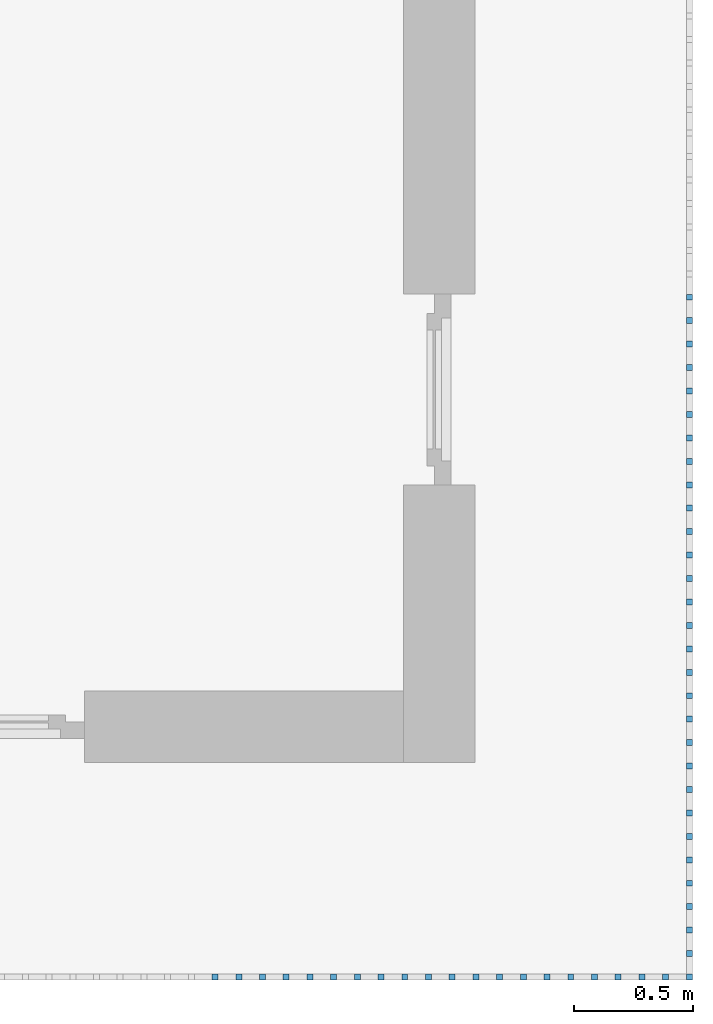
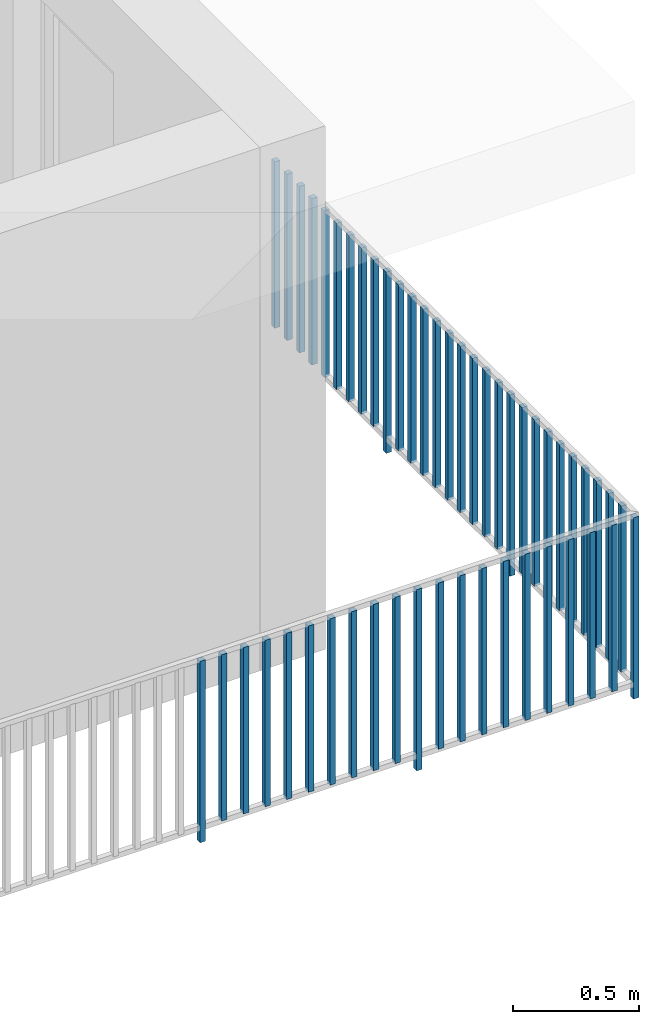
# One storey, part 37 of 48: 50 building element parts, 1 element without a shape of its own.
"""IFC4 building model written with IfcOpenShell, lengths in metres."""

from ifc_helpers import new_model, entity, si_unit, converted_unit, derived_unit, direction, frame, origin_with_axes, place, context, subcontext, project, spatial, polygons, material, type_object, element, aggregate, save


model = new_model("IFC4")

# Units and contexts
model_context = context("Model", 3, precision=1e-05, world=origin_with_axes(), true_north=direction((0.0, 1.0)))
body_context = subcontext(model_context, "Body", "Model", "MODEL_VIEW")
ifc_project = project(units=[si_unit("LENGTHUNIT", "METRE"), si_unit("AREAUNIT", "SQUARE_METRE"), si_unit("VOLUMEUNIT", "CUBIC_METRE"), converted_unit("PLANEANGLEUNIT", "DEGREE", entity("IfcPlaneAngleMeasure", 0.0174532925199), si_unit("PLANEANGLEUNIT", "RADIAN"), dimensions=[0, 0, 0, 0, 0, 0, 0]), converted_unit("TIMEUNIT", "Year", entity("IfcTimeMeasure", 31556926.0), si_unit("TIMEUNIT", "SECOND"), dimensions=[0, 0, 1, 0, 0, 0, 0]), si_unit("MASSUNIT", "GRAM", prefix="KILO"), si_unit("THERMODYNAMICTEMPERATUREUNIT", "DEGREE_CELSIUS"), si_unit("LUMINOUSINTENSITYUNIT", "LUMEN"), si_unit("ENERGYUNIT", "JOULE", prefix="MEGA"), derived_unit("THERMALCONDUCTANCEUNIT", [(si_unit("POWERUNIT", "WATT"), 1), (si_unit("LENGTHUNIT", "METRE"), -1), (si_unit("THERMODYNAMICTEMPERATUREUNIT", "KELVIN"), -1)]), derived_unit("SPECIFICHEATCAPACITYUNIT", [(si_unit("ENERGYUNIT", "JOULE"), 1), (si_unit("MASSUNIT", "GRAM", prefix="KILO"), -1), (si_unit("THERMODYNAMICTEMPERATUREUNIT", "KELVIN"), -1)]), derived_unit("MASSDENSITYUNIT", [(si_unit("MASSUNIT", "GRAM", prefix="KILO"), 1), (si_unit("VOLUMEUNIT", "CUBIC_METRE"), -1)])], contexts=[model_context])

# Site, building, storey
site_placement = place(None, origin_with_axes())
site = spatial("IfcSite", under=ifc_project, at=site_placement, CompositionType="ELEMENT")
building_placement = place(site_placement, origin_with_axes())
building = spatial("IfcBuilding", under=site, at=building_placement, CompositionType="ELEMENT")
storey_placement = place(building_placement, frame((0.0, 0.0, 3.4), z_axis=(0.0, 0.0, 1.0), x_axis=(1.0, 0.0, 0.0)))
storey = spatial("IfcBuildingStorey", under=building, at=storey_placement, Name="1. Geschoss", CompositionType="ELEMENT", Elevation=3.4)

# Railing, building element parts
railing_type = type_object("IfcRailingType", PredefinedType="NOTDEFINED")
railing_placement = place(storey_placement, frame((10.2378006196, 9.82118776896, 0.0), z_axis=(0.0, 0.0, 1.0), x_axis=(1.0, 0.0, 0.0)))
railing = element("IfcRailing", 1, at=railing_placement, inside=storey, type_object=railing_type, PredefinedType="NOTDEFINED")
ifc_material = material()
building_element_part_1_placement = place(railing_placement, origin_with_axes())
building_element_part_1 = element("IfcBuildingElementPart", 2, at=building_element_part_1_placement, material=ifc_material, PredefinedType="NOTDEFINED", context=body_context, shape_type="Tessellation", body=[
    polygons([(0.0125, -20.6625, 0.0), (0.0125, -20.6375, 0.0), (0.0125, -20.6375, 0.88), (0.0125, -20.6625, 0.88), (-0.0125, -20.6625, 0.0), (-0.0125, -20.6375, 0.0), (-0.0125, -20.6375, 0.88), (-0.0125, -20.6625, 0.88)], [[[1, 2, 3, 4]], [[1, 5, 6, 2]], [[2, 6, 7, 3]], [[4, 3, 7, 8]], [[5, 1, 4, 8]], [[6, 5, 8, 7]]], closed=True),
])
building_element_part_2_placement = place(railing_placement, origin_with_axes())
building_element_part_2 = element("IfcBuildingElementPart", 3, at=building_element_part_2_placement, material=ifc_material, PredefinedType="NOTDEFINED", context=body_context, shape_type="Tessellation", body=[
    polygons([(-1.97706521739, -20.6625, 0.0), (-1.97706521739, -20.6375, 0.0), (-1.97706521739, -20.6375, 0.88), (-1.97706521739, -20.6625, 0.88), (-2.00206521739, -20.6625, 0.0), (-2.00206521739, -20.6375, 0.0), (-2.00206521739, -20.6375, 0.88), (-2.00206521739, -20.6625, 0.88)], [[[1, 2, 3, 4]], [[1, 5, 6, 2]], [[2, 6, 7, 3]], [[4, 3, 7, 8]], [[5, 1, 4, 8]], [[6, 5, 8, 7]]], closed=True),
])
building_element_part_3_placement = place(railing_placement, origin_with_axes())
building_element_part_3 = element("IfcBuildingElementPart", 4, at=building_element_part_3_placement, material=ifc_material, PredefinedType="NOTDEFINED", context=body_context, shape_type="Tessellation", body=[
    polygons([(-1.87758695652, -20.6625, 0.07), (-1.87758695652, -20.6375, 0.07), (-1.87758695652, -20.6375, 0.8775), (-1.87758695652, -20.6625, 0.8775), (-1.90258695652, -20.6625, 0.07), (-1.90258695652, -20.6375, 0.07), (-1.90258695652, -20.6375, 0.8775), (-1.90258695652, -20.6625, 0.8775)], [[[1, 2, 3, 4]], [[1, 5, 6, 2]], [[2, 6, 7, 3]], [[4, 3, 7, 8]], [[5, 1, 4, 8]], [[6, 5, 8, 7]]], closed=True),
])
building_element_part_4_placement = place(railing_placement, origin_with_axes())
building_element_part_4 = element("IfcBuildingElementPart", 5, at=building_element_part_4_placement, material=ifc_material, PredefinedType="NOTDEFINED", context=body_context, shape_type="Tessellation", body=[
    polygons([(-1.77810869565, -20.6625, 0.07), (-1.77810869565, -20.6375, 0.07), (-1.77810869565, -20.6375, 0.8775), (-1.77810869565, -20.6625, 0.8775), (-1.80310869565, -20.6625, 0.07), (-1.80310869565, -20.6375, 0.07), (-1.80310869565, -20.6375, 0.8775), (-1.80310869565, -20.6625, 0.8775)], [[[1, 2, 3, 4]], [[1, 5, 6, 2]], [[2, 6, 7, 3]], [[4, 3, 7, 8]], [[5, 1, 4, 8]], [[6, 5, 8, 7]]], closed=True),
])
building_element_part_5_placement = place(railing_placement, origin_with_axes())
building_element_part_5 = element("IfcBuildingElementPart", 6, at=building_element_part_5_placement, material=ifc_material, PredefinedType="NOTDEFINED", context=body_context, shape_type="Tessellation", body=[
    polygons([(-1.67863043478, -20.6625, 0.07), (-1.67863043478, -20.6375, 0.07), (-1.67863043478, -20.6375, 0.8775), (-1.67863043478, -20.6625, 0.8775), (-1.70363043478, -20.6625, 0.07), (-1.70363043478, -20.6375, 0.07), (-1.70363043478, -20.6375, 0.8775), (-1.70363043478, -20.6625, 0.8775)], [[[1, 2, 3, 4]], [[1, 5, 6, 2]], [[2, 6, 7, 3]], [[4, 3, 7, 8]], [[5, 1, 4, 8]], [[6, 5, 8, 7]]], closed=True),
])
building_element_part_6_placement = place(railing_placement, origin_with_axes())
building_element_part_6 = element("IfcBuildingElementPart", 7, at=building_element_part_6_placement, material=ifc_material, PredefinedType="NOTDEFINED", context=body_context, shape_type="Tessellation", body=[
    polygons([(-1.57915217391, -20.6625, 0.07), (-1.57915217391, -20.6375, 0.07), (-1.57915217391, -20.6375, 0.8775), (-1.57915217391, -20.6625, 0.8775), (-1.60415217391, -20.6625, 0.07), (-1.60415217391, -20.6375, 0.07), (-1.60415217391, -20.6375, 0.8775), (-1.60415217391, -20.6625, 0.8775)], [[[1, 2, 3, 4]], [[1, 5, 6, 2]], [[2, 6, 7, 3]], [[4, 3, 7, 8]], [[5, 1, 4, 8]], [[6, 5, 8, 7]]], closed=True),
])
building_element_part_7_placement = place(railing_placement, origin_with_axes())
building_element_part_7 = element("IfcBuildingElementPart", 8, at=building_element_part_7_placement, material=ifc_material, PredefinedType="NOTDEFINED", context=body_context, shape_type="Tessellation", body=[
    polygons([(-1.47967391304, -20.6625, 0.07), (-1.47967391304, -20.6375, 0.07), (-1.47967391304, -20.6375, 0.8775), (-1.47967391304, -20.6625, 0.8775), (-1.50467391304, -20.6625, 0.07), (-1.50467391304, -20.6375, 0.07), (-1.50467391304, -20.6375, 0.8775), (-1.50467391304, -20.6625, 0.8775)], [[[1, 2, 3, 4]], [[1, 5, 6, 2]], [[2, 6, 7, 3]], [[4, 3, 7, 8]], [[5, 1, 4, 8]], [[6, 5, 8, 7]]], closed=True),
])
building_element_part_8_placement = place(railing_placement, origin_with_axes())
building_element_part_8 = element("IfcBuildingElementPart", 9, at=building_element_part_8_placement, material=ifc_material, PredefinedType="NOTDEFINED", context=body_context, shape_type="Tessellation", body=[
    polygons([(-1.38019565217, -20.6625, 0.07), (-1.38019565217, -20.6375, 0.07), (-1.38019565217, -20.6375, 0.8775), (-1.38019565217, -20.6625, 0.8775), (-1.40519565217, -20.6625, 0.07), (-1.40519565217, -20.6375, 0.07), (-1.40519565217, -20.6375, 0.8775), (-1.40519565217, -20.6625, 0.8775)], [[[1, 2, 3, 4]], [[1, 5, 6, 2]], [[2, 6, 7, 3]], [[4, 3, 7, 8]], [[5, 1, 4, 8]], [[6, 5, 8, 7]]], closed=True),
])
building_element_part_9_placement = place(railing_placement, origin_with_axes())
building_element_part_9 = element("IfcBuildingElementPart", 10, at=building_element_part_9_placement, material=ifc_material, PredefinedType="NOTDEFINED", context=body_context, shape_type="Tessellation", body=[
    polygons([(-1.2807173913, -20.6625, 0.07), (-1.2807173913, -20.6375, 0.07), (-1.2807173913, -20.6375, 0.8775), (-1.2807173913, -20.6625, 0.8775), (-1.3057173913, -20.6625, 0.07), (-1.3057173913, -20.6375, 0.07), (-1.3057173913, -20.6375, 0.8775), (-1.3057173913, -20.6625, 0.8775)], [[[1, 2, 3, 4]], [[1, 5, 6, 2]], [[2, 6, 7, 3]], [[4, 3, 7, 8]], [[5, 1, 4, 8]], [[6, 5, 8, 7]]], closed=True),
])
building_element_part_10_placement = place(railing_placement, origin_with_axes())
building_element_part_10 = element("IfcBuildingElementPart", 11, at=building_element_part_10_placement, material=ifc_material, PredefinedType="NOTDEFINED", context=body_context, shape_type="Tessellation", body=[
    polygons([(-1.18123913043, -20.6625, 0.07), (-1.18123913043, -20.6375, 0.07), (-1.18123913043, -20.6375, 0.8775), (-1.18123913043, -20.6625, 0.8775), (-1.20623913043, -20.6625, 0.07), (-1.20623913043, -20.6375, 0.07), (-1.20623913043, -20.6375, 0.8775), (-1.20623913043, -20.6625, 0.8775)], [[[1, 2, 3, 4]], [[1, 5, 6, 2]], [[2, 6, 7, 3]], [[4, 3, 7, 8]], [[5, 1, 4, 8]], [[6, 5, 8, 7]]], closed=True),
])
building_element_part_11_placement = place(railing_placement, origin_with_axes())
building_element_part_11 = element("IfcBuildingElementPart", 12, at=building_element_part_11_placement, material=ifc_material, PredefinedType="NOTDEFINED", context=body_context, shape_type="Tessellation", body=[
    polygons([(-1.08176086957, -20.6625, 0.07), (-1.08176086957, -20.6375, 0.07), (-1.08176086957, -20.6375, 0.8775), (-1.08176086957, -20.6625, 0.8775), (-1.10676086957, -20.6625, 0.07), (-1.10676086957, -20.6375, 0.07), (-1.10676086957, -20.6375, 0.8775), (-1.10676086957, -20.6625, 0.8775)], [[[1, 2, 3, 4]], [[1, 5, 6, 2]], [[2, 6, 7, 3]], [[4, 3, 7, 8]], [[5, 1, 4, 8]], [[6, 5, 8, 7]]], closed=True),
])
building_element_part_12_placement = place(railing_placement, origin_with_axes())
building_element_part_12 = element("IfcBuildingElementPart", 13, at=building_element_part_12_placement, material=ifc_material, PredefinedType="NOTDEFINED", context=body_context, shape_type="Tessellation", body=[
    polygons([(-0.982282608696, -20.6625, 0.0), (-0.982282608696, -20.6375, 0.0), (-0.982282608696, -20.6375, 0.88), (-0.982282608696, -20.6625, 0.88), (-1.0072826087, -20.6625, 0.0), (-1.0072826087, -20.6375, 0.0), (-1.0072826087, -20.6375, 0.88), (-1.0072826087, -20.6625, 0.88)], [[[1, 2, 3, 4]], [[1, 5, 6, 2]], [[2, 6, 7, 3]], [[4, 3, 7, 8]], [[5, 1, 4, 8]], [[6, 5, 8, 7]]], closed=True),
])
building_element_part_13_placement = place(railing_placement, origin_with_axes())
building_element_part_13 = element("IfcBuildingElementPart", 14, at=building_element_part_13_placement, material=ifc_material, PredefinedType="NOTDEFINED", context=body_context, shape_type="Tessellation", body=[
    polygons([(-0.882804347826, -20.6625, 0.07), (-0.882804347826, -20.6375, 0.07), (-0.882804347826, -20.6375, 0.8775), (-0.882804347826, -20.6625, 0.8775), (-0.907804347826, -20.6625, 0.07), (-0.907804347826, -20.6375, 0.07), (-0.907804347826, -20.6375, 0.8775), (-0.907804347826, -20.6625, 0.8775)], [[[1, 2, 3, 4]], [[1, 5, 6, 2]], [[2, 6, 7, 3]], [[4, 3, 7, 8]], [[5, 1, 4, 8]], [[6, 5, 8, 7]]], closed=True),
])
building_element_part_14_placement = place(railing_placement, origin_with_axes())
building_element_part_14 = element("IfcBuildingElementPart", 15, at=building_element_part_14_placement, material=ifc_material, PredefinedType="NOTDEFINED", context=body_context, shape_type="Tessellation", body=[
    polygons([(-0.783326086957, -20.6625, 0.07), (-0.783326086957, -20.6375, 0.07), (-0.783326086957, -20.6375, 0.8775), (-0.783326086957, -20.6625, 0.8775), (-0.808326086957, -20.6625, 0.07), (-0.808326086957, -20.6375, 0.07), (-0.808326086957, -20.6375, 0.8775), (-0.808326086957, -20.6625, 0.8775)], [[[1, 2, 3, 4]], [[1, 5, 6, 2]], [[2, 6, 7, 3]], [[4, 3, 7, 8]], [[5, 1, 4, 8]], [[6, 5, 8, 7]]], closed=True),
])
building_element_part_15_placement = place(railing_placement, origin_with_axes())
building_element_part_15 = element("IfcBuildingElementPart", 16, at=building_element_part_15_placement, material=ifc_material, PredefinedType="NOTDEFINED", context=body_context, shape_type="Tessellation", body=[
    polygons([(-0.683847826087, -20.6625, 0.07), (-0.683847826087, -20.6375, 0.07), (-0.683847826087, -20.6375, 0.8775), (-0.683847826087, -20.6625, 0.8775), (-0.708847826087, -20.6625, 0.07), (-0.708847826087, -20.6375, 0.07), (-0.708847826087, -20.6375, 0.8775), (-0.708847826087, -20.6625, 0.8775)], [[[1, 2, 3, 4]], [[1, 5, 6, 2]], [[2, 6, 7, 3]], [[4, 3, 7, 8]], [[5, 1, 4, 8]], [[6, 5, 8, 7]]], closed=True),
])
building_element_part_16_placement = place(railing_placement, origin_with_axes())
building_element_part_16 = element("IfcBuildingElementPart", 17, at=building_element_part_16_placement, material=ifc_material, PredefinedType="NOTDEFINED", context=body_context, shape_type="Tessellation", body=[
    polygons([(-0.584369565217, -20.6625, 0.07), (-0.584369565217, -20.6375, 0.07), (-0.584369565217, -20.6375, 0.8775), (-0.584369565217, -20.6625, 0.8775), (-0.609369565217, -20.6625, 0.07), (-0.609369565217, -20.6375, 0.07), (-0.609369565217, -20.6375, 0.8775), (-0.609369565217, -20.6625, 0.8775)], [[[1, 2, 3, 4]], [[1, 5, 6, 2]], [[2, 6, 7, 3]], [[4, 3, 7, 8]], [[5, 1, 4, 8]], [[6, 5, 8, 7]]], closed=True),
])
building_element_part_17_placement = place(railing_placement, origin_with_axes())
building_element_part_17 = element("IfcBuildingElementPart", 18, at=building_element_part_17_placement, material=ifc_material, PredefinedType="NOTDEFINED", context=body_context, shape_type="Tessellation", body=[
    polygons([(-0.484891304348, -20.6625, 0.07), (-0.484891304348, -20.6375, 0.07), (-0.484891304348, -20.6375, 0.8775), (-0.484891304348, -20.6625, 0.8775), (-0.509891304348, -20.6625, 0.07), (-0.509891304348, -20.6375, 0.07), (-0.509891304348, -20.6375, 0.8775), (-0.509891304348, -20.6625, 0.8775)], [[[1, 2, 3, 4]], [[1, 5, 6, 2]], [[2, 6, 7, 3]], [[4, 3, 7, 8]], [[5, 1, 4, 8]], [[6, 5, 8, 7]]], closed=True),
])
building_element_part_18_placement = place(railing_placement, origin_with_axes())
building_element_part_18 = element("IfcBuildingElementPart", 19, at=building_element_part_18_placement, material=ifc_material, PredefinedType="NOTDEFINED", context=body_context, shape_type="Tessellation", body=[
    polygons([(-0.385413043478, -20.6625, 0.07), (-0.385413043478, -20.6375, 0.07), (-0.385413043478, -20.6375, 0.8775), (-0.385413043478, -20.6625, 0.8775), (-0.410413043478, -20.6625, 0.07), (-0.410413043478, -20.6375, 0.07), (-0.410413043478, -20.6375, 0.8775), (-0.410413043478, -20.6625, 0.8775)], [[[1, 2, 3, 4]], [[1, 5, 6, 2]], [[2, 6, 7, 3]], [[4, 3, 7, 8]], [[5, 1, 4, 8]], [[6, 5, 8, 7]]], closed=True),
])
building_element_part_19_placement = place(railing_placement, origin_with_axes())
building_element_part_19 = element("IfcBuildingElementPart", 20, at=building_element_part_19_placement, material=ifc_material, PredefinedType="NOTDEFINED", context=body_context, shape_type="Tessellation", body=[
    polygons([(-0.285934782609, -20.6625, 0.07), (-0.285934782609, -20.6375, 0.07), (-0.285934782609, -20.6375, 0.8775), (-0.285934782609, -20.6625, 0.8775), (-0.310934782609, -20.6625, 0.07), (-0.310934782609, -20.6375, 0.07), (-0.310934782609, -20.6375, 0.8775), (-0.310934782609, -20.6625, 0.8775)], [[[1, 2, 3, 4]], [[1, 5, 6, 2]], [[2, 6, 7, 3]], [[4, 3, 7, 8]], [[5, 1, 4, 8]], [[6, 5, 8, 7]]], closed=True),
])
building_element_part_20_placement = place(railing_placement, origin_with_axes())
building_element_part_20 = element("IfcBuildingElementPart", 21, at=building_element_part_20_placement, material=ifc_material, PredefinedType="NOTDEFINED", context=body_context, shape_type="Tessellation", body=[
    polygons([(-0.186456521739, -20.6625, 0.07), (-0.186456521739, -20.6375, 0.07), (-0.186456521739, -20.6375, 0.8775), (-0.186456521739, -20.6625, 0.8775), (-0.211456521739, -20.6625, 0.07), (-0.211456521739, -20.6375, 0.07), (-0.211456521739, -20.6375, 0.8775), (-0.211456521739, -20.6625, 0.8775)], [[[1, 2, 3, 4]], [[1, 5, 6, 2]], [[2, 6, 7, 3]], [[4, 3, 7, 8]], [[5, 1, 4, 8]], [[6, 5, 8, 7]]], closed=True),
])
building_element_part_21_placement = place(railing_placement, origin_with_axes())
building_element_part_21 = element("IfcBuildingElementPart", 22, at=building_element_part_21_placement, material=ifc_material, PredefinedType="NOTDEFINED", context=body_context, shape_type="Tessellation", body=[
    polygons([(-0.0869782608696, -20.6625, 0.07), (-0.0869782608696, -20.6375, 0.07), (-0.0869782608696, -20.6375, 0.8775), (-0.0869782608696, -20.6625, 0.8775), (-0.11197826087, -20.6625, 0.07), (-0.11197826087, -20.6375, 0.07), (-0.11197826087, -20.6375, 0.8775), (-0.11197826087, -20.6625, 0.8775)], [[[1, 2, 3, 4]], [[1, 5, 6, 2]], [[2, 6, 7, 3]], [[4, 3, 7, 8]], [[5, 1, 4, 8]], [[6, 5, 8, 7]]], closed=True),
])
building_element_part_22_placement = place(railing_placement, origin_with_axes())
building_element_part_22 = element("IfcBuildingElementPart", 23, at=building_element_part_22_placement, material=ifc_material, PredefinedType="NOTDEFINED", context=body_context, shape_type="Tessellation", body=[
    polygons([(0.0125, -20.5391666667, 0.07), (-0.0125, -20.5391666667, 0.07), (-0.0125, -20.5391666667, 0.8775), (0.0125, -20.5391666667, 0.8775), (0.0125, -20.5641666667, 0.07), (-0.0125, -20.5641666667, 0.07), (-0.0125, -20.5641666667, 0.8775), (0.0125, -20.5641666667, 0.8775)], [[[1, 2, 3, 4]], [[1, 5, 6, 2]], [[2, 6, 7, 3]], [[4, 3, 7, 8]], [[5, 1, 4, 8]], [[6, 5, 8, 7]]], closed=True),
])
building_element_part_23_placement = place(railing_placement, origin_with_axes())
building_element_part_23 = element("IfcBuildingElementPart", 24, at=building_element_part_23_placement, material=ifc_material, PredefinedType="NOTDEFINED", context=body_context, shape_type="Tessellation", body=[
    polygons([(0.0125, -20.4408333333, 0.07), (-0.0125, -20.4408333333, 0.07), (-0.0125, -20.4408333333, 0.8775), (0.0125, -20.4408333333, 0.8775), (0.0125, -20.4658333333, 0.07), (-0.0125, -20.4658333333, 0.07), (-0.0125, -20.4658333333, 0.8775), (0.0125, -20.4658333333, 0.8775)], [[[1, 2, 3, 4]], [[1, 5, 6, 2]], [[2, 6, 7, 3]], [[4, 3, 7, 8]], [[5, 1, 4, 8]], [[6, 5, 8, 7]]], closed=True),
])
building_element_part_24_placement = place(railing_placement, origin_with_axes())
building_element_part_24 = element("IfcBuildingElementPart", 25, at=building_element_part_24_placement, material=ifc_material, PredefinedType="NOTDEFINED", context=body_context, shape_type="Tessellation", body=[
    polygons([(0.0125, -20.3425, 0.07), (-0.0125, -20.3425, 0.07), (-0.0125, -20.3425, 0.8775), (0.0125, -20.3425, 0.8775), (0.0125, -20.3675, 0.07), (-0.0125, -20.3675, 0.07), (-0.0125, -20.3675, 0.8775), (0.0125, -20.3675, 0.8775)], [[[1, 2, 3, 4]], [[1, 5, 6, 2]], [[2, 6, 7, 3]], [[4, 3, 7, 8]], [[5, 1, 4, 8]], [[6, 5, 8, 7]]], closed=True),
])
building_element_part_25_placement = place(railing_placement, origin_with_axes())
building_element_part_25 = element("IfcBuildingElementPart", 26, at=building_element_part_25_placement, material=ifc_material, PredefinedType="NOTDEFINED", context=body_context, shape_type="Tessellation", body=[
    polygons([(0.0125, -20.2441666667, 0.07), (-0.0125, -20.2441666667, 0.07), (-0.0125, -20.2441666667, 0.8775), (0.0125, -20.2441666667, 0.8775), (0.0125, -20.2691666667, 0.07), (-0.0125, -20.2691666667, 0.07), (-0.0125, -20.2691666667, 0.8775), (0.0125, -20.2691666667, 0.8775)], [[[1, 2, 3, 4]], [[1, 5, 6, 2]], [[2, 6, 7, 3]], [[4, 3, 7, 8]], [[5, 1, 4, 8]], [[6, 5, 8, 7]]], closed=True),
])
building_element_part_26_placement = place(railing_placement, origin_with_axes())
building_element_part_26 = element("IfcBuildingElementPart", 27, at=building_element_part_26_placement, material=ifc_material, PredefinedType="NOTDEFINED", context=body_context, shape_type="Tessellation", body=[
    polygons([(0.0125, -20.1458333333, 0.07), (-0.0125, -20.1458333333, 0.07), (-0.0125, -20.1458333333, 0.8775), (0.0125, -20.1458333333, 0.8775), (0.0125, -20.1708333333, 0.07), (-0.0125, -20.1708333333, 0.07), (-0.0125, -20.1708333333, 0.8775), (0.0125, -20.1708333333, 0.8775)], [[[1, 2, 3, 4]], [[1, 5, 6, 2]], [[2, 6, 7, 3]], [[4, 3, 7, 8]], [[5, 1, 4, 8]], [[6, 5, 8, 7]]], closed=True),
])
building_element_part_27_placement = place(railing_placement, origin_with_axes())
building_element_part_27 = element("IfcBuildingElementPart", 28, at=building_element_part_27_placement, material=ifc_material, PredefinedType="NOTDEFINED", context=body_context, shape_type="Tessellation", body=[
    polygons([(0.0125, -20.0475, 0.07), (-0.0125, -20.0475, 0.07), (-0.0125, -20.0475, 0.8775), (0.0125, -20.0475, 0.8775), (0.0125, -20.0725, 0.07), (-0.0125, -20.0725, 0.07), (-0.0125, -20.0725, 0.8775), (0.0125, -20.0725, 0.8775)], [[[1, 2, 3, 4]], [[1, 5, 6, 2]], [[2, 6, 7, 3]], [[4, 3, 7, 8]], [[5, 1, 4, 8]], [[6, 5, 8, 7]]], closed=True),
])
building_element_part_28_placement = place(railing_placement, origin_with_axes())
building_element_part_28 = element("IfcBuildingElementPart", 29, at=building_element_part_28_placement, material=ifc_material, PredefinedType="NOTDEFINED", context=body_context, shape_type="Tessellation", body=[
    polygons([(0.0125, -19.9491666667, 0.07), (-0.0125, -19.9491666667, 0.07), (-0.0125, -19.9491666667, 0.8775), (0.0125, -19.9491666667, 0.8775), (0.0125, -19.9741666667, 0.07), (-0.0125, -19.9741666667, 0.07), (-0.0125, -19.9741666667, 0.8775), (0.0125, -19.9741666667, 0.8775)], [[[1, 2, 3, 4]], [[1, 5, 6, 2]], [[2, 6, 7, 3]], [[4, 3, 7, 8]], [[5, 1, 4, 8]], [[6, 5, 8, 7]]], closed=True),
])
building_element_part_29_placement = place(railing_placement, origin_with_axes())
building_element_part_29 = element("IfcBuildingElementPart", 30, at=building_element_part_29_placement, material=ifc_material, PredefinedType="NOTDEFINED", context=body_context, shape_type="Tessellation", body=[
    polygons([(0.0125, -19.8508333333, 0.07), (-0.0125, -19.8508333333, 0.07), (-0.0125, -19.8508333333, 0.8775), (0.0125, -19.8508333333, 0.8775), (0.0125, -19.8758333333, 0.07), (-0.0125, -19.8758333333, 0.07), (-0.0125, -19.8758333333, 0.8775), (0.0125, -19.8758333333, 0.8775)], [[[1, 2, 3, 4]], [[1, 5, 6, 2]], [[2, 6, 7, 3]], [[4, 3, 7, 8]], [[5, 1, 4, 8]], [[6, 5, 8, 7]]], closed=True),
])
building_element_part_30_placement = place(railing_placement, origin_with_axes())
building_element_part_30 = element("IfcBuildingElementPart", 31, at=building_element_part_30_placement, material=ifc_material, PredefinedType="NOTDEFINED", context=body_context, shape_type="Tessellation", body=[
    polygons([(0.0125, -19.7525, 0.07), (-0.0125, -19.7525, 0.07), (-0.0125, -19.7525, 0.8775), (0.0125, -19.7525, 0.8775), (0.0125, -19.7775, 0.07), (-0.0125, -19.7775, 0.07), (-0.0125, -19.7775, 0.8775), (0.0125, -19.7775, 0.8775)], [[[1, 2, 3, 4]], [[1, 5, 6, 2]], [[2, 6, 7, 3]], [[4, 3, 7, 8]], [[5, 1, 4, 8]], [[6, 5, 8, 7]]], closed=True),
])
building_element_part_31_placement = place(railing_placement, origin_with_axes())
building_element_part_31 = element("IfcBuildingElementPart", 32, at=building_element_part_31_placement, material=ifc_material, PredefinedType="NOTDEFINED", context=body_context, shape_type="Tessellation", body=[
    polygons([(0.0125, -19.6541666667, 0.0), (-0.0125, -19.6541666667, 0.0), (-0.0125, -19.6541666667, 0.88), (0.0125, -19.6541666667, 0.88), (0.0125, -19.6791666667, 0.0), (-0.0125, -19.6791666667, 0.0), (-0.0125, -19.6791666667, 0.88), (0.0125, -19.6791666667, 0.88)], [[[1, 2, 3, 4]], [[1, 5, 6, 2]], [[2, 6, 7, 3]], [[4, 3, 7, 8]], [[5, 1, 4, 8]], [[6, 5, 8, 7]]], closed=True),
])
building_element_part_32_placement = place(railing_placement, origin_with_axes())
building_element_part_32 = element("IfcBuildingElementPart", 33, at=building_element_part_32_placement, material=ifc_material, PredefinedType="NOTDEFINED", context=body_context, shape_type="Tessellation", body=[
    polygons([(0.0125, -19.5558333333, 0.07), (-0.0125, -19.5558333333, 0.07), (-0.0125, -19.5558333333, 0.8775), (0.0125, -19.5558333333, 0.8775), (0.0125, -19.5808333333, 0.07), (-0.0125, -19.5808333333, 0.07), (-0.0125, -19.5808333333, 0.8775), (0.0125, -19.5808333333, 0.8775)], [[[1, 2, 3, 4]], [[1, 5, 6, 2]], [[2, 6, 7, 3]], [[4, 3, 7, 8]], [[5, 1, 4, 8]], [[6, 5, 8, 7]]], closed=True),
])
building_element_part_33_placement = place(railing_placement, origin_with_axes())
building_element_part_33 = element("IfcBuildingElementPart", 34, at=building_element_part_33_placement, material=ifc_material, PredefinedType="NOTDEFINED", context=body_context, shape_type="Tessellation", body=[
    polygons([(0.0125, -19.4575, 0.07), (-0.0125, -19.4575, 0.07), (-0.0125, -19.4575, 0.8775), (0.0125, -19.4575, 0.8775), (0.0125, -19.4825, 0.07), (-0.0125, -19.4825, 0.07), (-0.0125, -19.4825, 0.8775), (0.0125, -19.4825, 0.8775)], [[[1, 2, 3, 4]], [[1, 5, 6, 2]], [[2, 6, 7, 3]], [[4, 3, 7, 8]], [[5, 1, 4, 8]], [[6, 5, 8, 7]]], closed=True),
])
building_element_part_34_placement = place(railing_placement, origin_with_axes())
building_element_part_34 = element("IfcBuildingElementPart", 35, at=building_element_part_34_placement, material=ifc_material, PredefinedType="NOTDEFINED", context=body_context, shape_type="Tessellation", body=[
    polygons([(0.0125, -19.3591666667, 0.07), (-0.0125, -19.3591666667, 0.07), (-0.0125, -19.3591666667, 0.8775), (0.0125, -19.3591666667, 0.8775), (0.0125, -19.3841666667, 0.07), (-0.0125, -19.3841666667, 0.07), (-0.0125, -19.3841666667, 0.8775), (0.0125, -19.3841666667, 0.8775)], [[[1, 2, 3, 4]], [[1, 5, 6, 2]], [[2, 6, 7, 3]], [[4, 3, 7, 8]], [[5, 1, 4, 8]], [[6, 5, 8, 7]]], closed=True),
])
building_element_part_35_placement = place(railing_placement, origin_with_axes())
building_element_part_35 = element("IfcBuildingElementPart", 36, at=building_element_part_35_placement, material=ifc_material, PredefinedType="NOTDEFINED", context=body_context, shape_type="Tessellation", body=[
    polygons([(0.0125, -19.2608333333, 0.07), (-0.0125, -19.2608333333, 0.07), (-0.0125, -19.2608333333, 0.8775), (0.0125, -19.2608333333, 0.8775), (0.0125, -19.2858333333, 0.07), (-0.0125, -19.2858333333, 0.07), (-0.0125, -19.2858333333, 0.8775), (0.0125, -19.2858333333, 0.8775)], [[[1, 2, 3, 4]], [[1, 5, 6, 2]], [[2, 6, 7, 3]], [[4, 3, 7, 8]], [[5, 1, 4, 8]], [[6, 5, 8, 7]]], closed=True),
])
building_element_part_36_placement = place(railing_placement, origin_with_axes())
building_element_part_36 = element("IfcBuildingElementPart", 37, at=building_element_part_36_placement, material=ifc_material, PredefinedType="NOTDEFINED", context=body_context, shape_type="Tessellation", body=[
    polygons([(0.0125, -19.1625, 0.07), (-0.0125, -19.1625, 0.07), (-0.0125, -19.1625, 0.8775), (0.0125, -19.1625, 0.8775), (0.0125, -19.1875, 0.07), (-0.0125, -19.1875, 0.07), (-0.0125, -19.1875, 0.8775), (0.0125, -19.1875, 0.8775)], [[[1, 2, 3, 4]], [[1, 5, 6, 2]], [[2, 6, 7, 3]], [[4, 3, 7, 8]], [[5, 1, 4, 8]], [[6, 5, 8, 7]]], closed=True),
])
building_element_part_37_placement = place(railing_placement, origin_with_axes())
building_element_part_37 = element("IfcBuildingElementPart", 38, at=building_element_part_37_placement, material=ifc_material, PredefinedType="NOTDEFINED", context=body_context, shape_type="Tessellation", body=[
    polygons([(0.0125, -19.0641666667, 0.07), (-0.0125, -19.0641666667, 0.07), (-0.0125, -19.0641666667, 0.8775), (0.0125, -19.0641666667, 0.8775), (0.0125, -19.0891666667, 0.07), (-0.0125, -19.0891666667, 0.07), (-0.0125, -19.0891666667, 0.8775), (0.0125, -19.0891666667, 0.8775)], [[[1, 2, 3, 4]], [[1, 5, 6, 2]], [[2, 6, 7, 3]], [[4, 3, 7, 8]], [[5, 1, 4, 8]], [[6, 5, 8, 7]]], closed=True),
])
building_element_part_38_placement = place(railing_placement, origin_with_axes())
building_element_part_38 = element("IfcBuildingElementPart", 39, at=building_element_part_38_placement, material=ifc_material, PredefinedType="NOTDEFINED", context=body_context, shape_type="Tessellation", body=[
    polygons([(0.0125, -18.9658333333, 0.07), (-0.0125, -18.9658333333, 0.07), (-0.0125, -18.9658333333, 0.8775), (0.0125, -18.9658333333, 0.8775), (0.0125, -18.9908333333, 0.07), (-0.0125, -18.9908333333, 0.07), (-0.0125, -18.9908333333, 0.8775), (0.0125, -18.9908333333, 0.8775)], [[[1, 2, 3, 4]], [[1, 5, 6, 2]], [[2, 6, 7, 3]], [[4, 3, 7, 8]], [[5, 1, 4, 8]], [[6, 5, 8, 7]]], closed=True),
])
building_element_part_39_placement = place(railing_placement, origin_with_axes())
building_element_part_39 = element("IfcBuildingElementPart", 40, at=building_element_part_39_placement, material=ifc_material, PredefinedType="NOTDEFINED", context=body_context, shape_type="Tessellation", body=[
    polygons([(0.0125, -18.8675, 0.07), (-0.0125, -18.8675, 0.07), (-0.0125, -18.8675, 0.8775), (0.0125, -18.8675, 0.8775), (0.0125, -18.8925, 0.07), (-0.0125, -18.8925, 0.07), (-0.0125, -18.8925, 0.8775), (0.0125, -18.8925, 0.8775)], [[[1, 2, 3, 4]], [[1, 5, 6, 2]], [[2, 6, 7, 3]], [[4, 3, 7, 8]], [[5, 1, 4, 8]], [[6, 5, 8, 7]]], closed=True),
])
building_element_part_40_placement = place(railing_placement, origin_with_axes())
building_element_part_40 = element("IfcBuildingElementPart", 41, at=building_element_part_40_placement, material=ifc_material, PredefinedType="NOTDEFINED", context=body_context, shape_type="Tessellation", body=[
    polygons([(0.0125, -18.7691666667, 0.07), (-0.0125, -18.7691666667, 0.07), (-0.0125, -18.7691666667, 0.8775), (0.0125, -18.7691666667, 0.8775), (0.0125, -18.7941666667, 0.07), (-0.0125, -18.7941666667, 0.07), (-0.0125, -18.7941666667, 0.8775), (0.0125, -18.7941666667, 0.8775)], [[[1, 2, 3, 4]], [[1, 5, 6, 2]], [[2, 6, 7, 3]], [[4, 3, 7, 8]], [[5, 1, 4, 8]], [[6, 5, 8, 7]]], closed=True),
])
building_element_part_41_placement = place(railing_placement, origin_with_axes())
building_element_part_41 = element("IfcBuildingElementPart", 42, at=building_element_part_41_placement, material=ifc_material, PredefinedType="NOTDEFINED", context=body_context, shape_type="Tessellation", body=[
    polygons([(0.0125, -18.6708333333, 0.0), (-0.0125, -18.6708333333, 0.0), (-0.0125, -18.6708333333, 0.88), (0.0125, -18.6708333333, 0.88), (0.0125, -18.6958333333, 0.0), (-0.0125, -18.6958333333, 0.0), (-0.0125, -18.6958333333, 0.88), (0.0125, -18.6958333333, 0.88)], [[[1, 2, 3, 4]], [[1, 5, 6, 2]], [[2, 6, 7, 3]], [[4, 3, 7, 8]], [[5, 1, 4, 8]], [[6, 5, 8, 7]]], closed=True),
])
building_element_part_42_placement = place(railing_placement, origin_with_axes())
building_element_part_42 = element("IfcBuildingElementPart", 43, at=building_element_part_42_placement, material=ifc_material, PredefinedType="NOTDEFINED", context=body_context, shape_type="Tessellation", body=[
    polygons([(0.0125, -18.5725, 0.07), (-0.0125, -18.5725, 0.07), (-0.0125, -18.5725, 0.8775), (0.0125, -18.5725, 0.8775), (0.0125, -18.5975, 0.07), (-0.0125, -18.5975, 0.07), (-0.0125, -18.5975, 0.8775), (0.0125, -18.5975, 0.8775)], [[[1, 2, 3, 4]], [[1, 5, 6, 2]], [[2, 6, 7, 3]], [[4, 3, 7, 8]], [[5, 1, 4, 8]], [[6, 5, 8, 7]]], closed=True),
])
building_element_part_43_placement = place(railing_placement, origin_with_axes())
building_element_part_43 = element("IfcBuildingElementPart", 44, at=building_element_part_43_placement, material=ifc_material, PredefinedType="NOTDEFINED", context=body_context, shape_type="Tessellation", body=[
    polygons([(0.0125, -18.4741666667, 0.07), (-0.0125, -18.4741666667, 0.07), (-0.0125, -18.4741666667, 0.8775), (0.0125, -18.4741666667, 0.8775), (0.0125, -18.4991666667, 0.07), (-0.0125, -18.4991666667, 0.07), (-0.0125, -18.4991666667, 0.8775), (0.0125, -18.4991666667, 0.8775)], [[[1, 2, 3, 4]], [[1, 5, 6, 2]], [[2, 6, 7, 3]], [[4, 3, 7, 8]], [[5, 1, 4, 8]], [[6, 5, 8, 7]]], closed=True),
])
building_element_part_44_placement = place(railing_placement, origin_with_axes())
building_element_part_44 = element("IfcBuildingElementPart", 45, at=building_element_part_44_placement, material=ifc_material, PredefinedType="NOTDEFINED", context=body_context, shape_type="Tessellation", body=[
    polygons([(0.0125, -18.3758333333, 0.07), (-0.0125, -18.3758333333, 0.07), (-0.0125, -18.3758333333, 0.8775), (0.0125, -18.3758333333, 0.8775), (0.0125, -18.4008333333, 0.07), (-0.0125, -18.4008333333, 0.07), (-0.0125, -18.4008333333, 0.8775), (0.0125, -18.4008333333, 0.8775)], [[[1, 2, 3, 4]], [[1, 5, 6, 2]], [[2, 6, 7, 3]], [[4, 3, 7, 8]], [[5, 1, 4, 8]], [[6, 5, 8, 7]]], closed=True),
])
building_element_part_45_placement = place(railing_placement, origin_with_axes())
building_element_part_45 = element("IfcBuildingElementPart", 46, at=building_element_part_45_placement, material=ifc_material, PredefinedType="NOTDEFINED", context=body_context, shape_type="Tessellation", body=[
    polygons([(0.0125, -18.2775, 0.07), (-0.0125, -18.2775, 0.07), (-0.0125, -18.2775, 0.8775), (0.0125, -18.2775, 0.8775), (0.0125, -18.3025, 0.07), (-0.0125, -18.3025, 0.07), (-0.0125, -18.3025, 0.8775), (0.0125, -18.3025, 0.8775)], [[[1, 2, 3, 4]], [[1, 5, 6, 2]], [[2, 6, 7, 3]], [[4, 3, 7, 8]], [[5, 1, 4, 8]], [[6, 5, 8, 7]]], closed=True),
])
building_element_part_46_placement = place(railing_placement, origin_with_axes())
building_element_part_46 = element("IfcBuildingElementPart", 47, at=building_element_part_46_placement, material=ifc_material, PredefinedType="NOTDEFINED", context=body_context, shape_type="Tessellation", body=[
    polygons([(0.0125, -18.1791666667, 0.07), (-0.0125, -18.1791666667, 0.07), (-0.0125, -18.1791666667, 0.8775), (0.0125, -18.1791666667, 0.8775), (0.0125, -18.2041666667, 0.07), (-0.0125, -18.2041666667, 0.07), (-0.0125, -18.2041666667, 0.8775), (0.0125, -18.2041666667, 0.8775)], [[[1, 2, 3, 4]], [[1, 5, 6, 2]], [[2, 6, 7, 3]], [[4, 3, 7, 8]], [[5, 1, 4, 8]], [[6, 5, 8, 7]]], closed=True),
])
building_element_part_47_placement = place(railing_placement, origin_with_axes())
building_element_part_47 = element("IfcBuildingElementPart", 48, at=building_element_part_47_placement, material=ifc_material, PredefinedType="NOTDEFINED", context=body_context, shape_type="Tessellation", body=[
    polygons([(0.0125, -18.0808333333, 0.07), (-0.0125, -18.0808333333, 0.07), (-0.0125, -18.0808333333, 0.8775), (0.0125, -18.0808333333, 0.8775), (0.0125, -18.1058333333, 0.07), (-0.0125, -18.1058333333, 0.07), (-0.0125, -18.1058333333, 0.8775), (0.0125, -18.1058333333, 0.8775)], [[[1, 2, 3, 4]], [[1, 5, 6, 2]], [[2, 6, 7, 3]], [[4, 3, 7, 8]], [[5, 1, 4, 8]], [[6, 5, 8, 7]]], closed=True),
])
building_element_part_48_placement = place(railing_placement, origin_with_axes())
building_element_part_48 = element("IfcBuildingElementPart", 49, at=building_element_part_48_placement, material=ifc_material, PredefinedType="NOTDEFINED", context=body_context, shape_type="Tessellation", body=[
    polygons([(0.0125, -17.9825, 0.07), (-0.0125, -17.9825, 0.07), (-0.0125, -17.9825, 0.8775), (0.0125, -17.9825, 0.8775), (0.0125, -18.0075, 0.07), (-0.0125, -18.0075, 0.07), (-0.0125, -18.0075, 0.8775), (0.0125, -18.0075, 0.8775)], [[[1, 2, 3, 4]], [[1, 5, 6, 2]], [[2, 6, 7, 3]], [[4, 3, 7, 8]], [[5, 1, 4, 8]], [[6, 5, 8, 7]]], closed=True),
])
building_element_part_49_placement = place(railing_placement, origin_with_axes())
building_element_part_49 = element("IfcBuildingElementPart", 50, at=building_element_part_49_placement, material=ifc_material, PredefinedType="NOTDEFINED", context=body_context, shape_type="Tessellation", body=[
    polygons([(0.0125, -17.8841666667, 0.07), (-0.0125, -17.8841666667, 0.07), (-0.0125, -17.8841666667, 0.8775), (0.0125, -17.8841666667, 0.8775), (0.0125, -17.9091666667, 0.07), (-0.0125, -17.9091666667, 0.07), (-0.0125, -17.9091666667, 0.8775), (0.0125, -17.9091666667, 0.8775)], [[[1, 2, 3, 4]], [[1, 5, 6, 2]], [[2, 6, 7, 3]], [[4, 3, 7, 8]], [[5, 1, 4, 8]], [[6, 5, 8, 7]]], closed=True),
])
building_element_part_50_placement = place(railing_placement, origin_with_axes())
building_element_part_50 = element("IfcBuildingElementPart", 51, at=building_element_part_50_placement, material=ifc_material, PredefinedType="NOTDEFINED", context=body_context, shape_type="Tessellation", body=[
    polygons([(0.0125, -17.7858333333, 0.07), (-0.0125, -17.7858333333, 0.07), (-0.0125, -17.7858333333, 0.8775), (0.0125, -17.7858333333, 0.8775), (0.0125, -17.8108333333, 0.07), (-0.0125, -17.8108333333, 0.07), (-0.0125, -17.8108333333, 0.8775), (0.0125, -17.8108333333, 0.8775)], [[[1, 2, 3, 4]], [[1, 5, 6, 2]], [[2, 6, 7, 3]], [[4, 3, 7, 8]], [[5, 1, 4, 8]], [[6, 5, 8, 7]]], closed=True),
])
aggregate(railing, [building_element_part_1, building_element_part_2, building_element_part_3, building_element_part_4, building_element_part_5, building_element_part_6, building_element_part_7, building_element_part_8, building_element_part_9, building_element_part_10, building_element_part_11, building_element_part_12, building_element_part_13, building_element_part_14, building_element_part_15, building_element_part_16, building_element_part_17, building_element_part_18, building_element_part_19, building_element_part_20, building_element_part_21, building_element_part_22, building_element_part_23, building_element_part_24, building_element_part_25, building_element_part_26, building_element_part_27, building_element_part_28, building_element_part_29, building_element_part_30, building_element_part_31, building_element_part_32, building_element_part_33, building_element_part_34, building_element_part_35, building_element_part_36, building_element_part_37, building_element_part_38, building_element_part_39, building_element_part_40, building_element_part_41, building_element_part_42, building_element_part_43, building_element_part_44, building_element_part_45, building_element_part_46, building_element_part_47, building_element_part_48, building_element_part_49, building_element_part_50])

save(model, "model.ifc")
